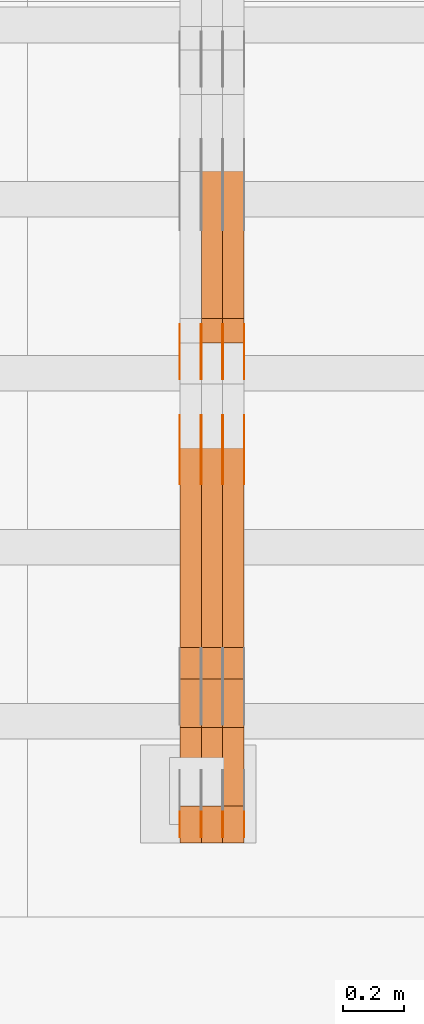
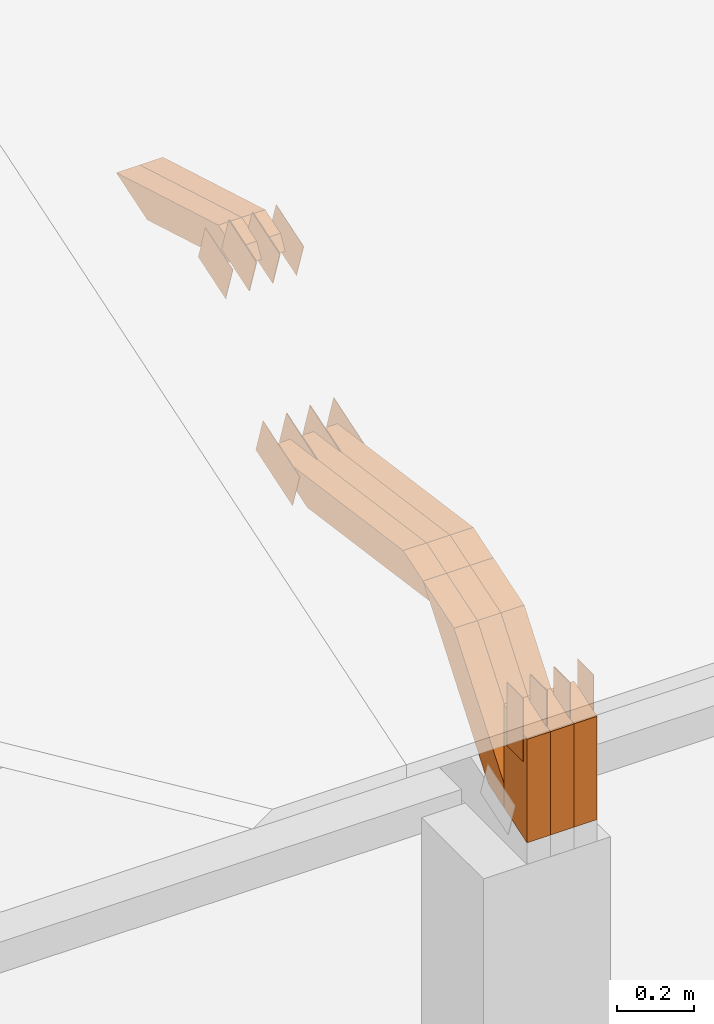
# One storey, part 122 of 385: 29 proxies.
"""IFC2X3 building model written with IfcOpenShell, lengths in millimetres."""

from ifc_helpers import new_model, entity, si_unit, converted_unit, derived_unit, direction, frame, frame_2d, origin, place, context, subcontext, project, spatial, polyline, rectangle, outline, extrude, source, transform, mapped, material, type_object, type_shapes, element, save


model = new_model("IFC2X3")

# Units and contexts
model_context = context("Model", 3, precision=0.01, world=origin(), true_north=direction((6.12303176911189e-17, 1.0)))
body_context = subcontext(model_context, "Body", "Model", "MODEL_VIEW")
ifc_project = project(units=[si_unit("LENGTHUNIT", "METRE", prefix="MILLI"), si_unit("AREAUNIT", "SQUARE_METRE"), si_unit("VOLUMEUNIT", "CUBIC_METRE"), converted_unit("PLANEANGLEUNIT", "DEGREE", entity("IfcRatioMeasure", 0.0174532925199433), si_unit("PLANEANGLEUNIT", "RADIAN"), dimensions=[0, 0, 0, 0, 0, 0, 0]), si_unit("MASSUNIT", "GRAM", prefix="KILO"), derived_unit("MASSDENSITYUNIT", [(si_unit("MASSUNIT", "GRAM", prefix="KILO"), 1), (si_unit("LENGTHUNIT", "METRE"), -3)]), si_unit("TIMEUNIT", "SECOND"), si_unit("FREQUENCYUNIT", "HERTZ"), si_unit("THERMODYNAMICTEMPERATUREUNIT", "DEGREE_CELSIUS"), derived_unit("THERMALTRANSMITTANCEUNIT", [(si_unit("MASSUNIT", "GRAM", prefix="KILO"), 1), (si_unit("THERMODYNAMICTEMPERATUREUNIT", "KELVIN"), -1), (si_unit("TIMEUNIT", "SECOND"), -3)]), derived_unit("VOLUMETRICFLOWRATEUNIT", [(si_unit("LENGTHUNIT", "METRE"), 3), (si_unit("TIMEUNIT", "SECOND"), -1)]), si_unit("ELECTRICCURRENTUNIT", "AMPERE"), si_unit("ELECTRICVOLTAGEUNIT", "VOLT"), si_unit("POWERUNIT", "WATT"), si_unit("FORCEUNIT", "NEWTON", prefix="KILO"), si_unit("ILLUMINANCEUNIT", "LUX"), si_unit("LUMINOUSFLUXUNIT", "LUMEN"), si_unit("LUMINOUSINTENSITYUNIT", "CANDELA"), derived_unit("USERDEFINED", [(si_unit("MASSUNIT", "GRAM", prefix="KILO"), -1), (si_unit("LENGTHUNIT", "METRE"), -2), (si_unit("TIMEUNIT", "SECOND"), 3), (si_unit("LUMINOUSFLUXUNIT", "LUMEN"), 1)]), derived_unit("LINEARVELOCITYUNIT", [(si_unit("LENGTHUNIT", "METRE"), 1), (si_unit("TIMEUNIT", "SECOND"), -1)]), si_unit("PRESSUREUNIT", "PASCAL"), derived_unit("USERDEFINED", [(si_unit("LENGTHUNIT", "METRE"), -2), (si_unit("MASSUNIT", "GRAM", prefix="KILO"), 1), (si_unit("TIMEUNIT", "SECOND"), -2)])], contexts=[model_context])

# Site, building, storey
site_placement = place(None, origin())
site = spatial("IfcSite", under=ifc_project, at=site_placement, CompositionType="ELEMENT")
building_placement = place(site_placement, origin())
building = spatial("IfcBuilding", under=site, at=building_placement, CompositionType="ELEMENT")
storey_placement = place(building_placement, origin())
storey = spatial("IfcBuildingStorey", under=building, at=storey_placement, Name="Default", CompositionType="ELEMENT", Elevation=0.0)

# Proxies
ifc_material_1 = material(Name="IfcSurfaceStyle #305254")
building_element_proxy_type_1 = type_object("IfcBuildingElementProxyType", PredefinedType="NOTDEFINED", material=ifc_material_1)
shared_shape_1 = source(origin(), body_context, "Body", "SweptSolid", [
    extrude(outline(polyline([(-99.9998204243802, -60.000067376167), (99.9998338462265, -60.000067376167), (99.9998204243802, 60.000067376167), (-99.9998338462265, 60.000067376167), (-99.9998204243802, -60.000067376167)])), frame((100.000602015329, 60.0001864986889, 0.0), z_axis=(0.0, 0.0, 1.0), x_axis=(-1.0, 0.0, 0.0)), (0.0, 0.0, 1.0), 1.3),
])
type_shapes(building_element_proxy_type_1, [shared_shape_1])
proxy_1_placement = place(building_placement, frame((24386.3, 4114.85465165112, 513.097031388771), z_axis=(-1.0, 0.0, 0.0), x_axis=(0.0, 0.951056516295124, 0.309016994375039)))
element("IfcBuildingElementProxy", 1, at=proxy_1_placement, inside=storey, type_object=building_element_proxy_type_1, material=ifc_material_1, context=body_context, shape_type="MappedRepresentation", body=[
    mapped(shared_shape_1, transform((0.0, 0.0, 0.0), scale=1.0)),
])
ifc_material_2 = material(Name="IfcSurfaceStyle #305197")
building_element_proxy_type_2 = type_object("IfcBuildingElementProxyType", PredefinedType="NOTDEFINED", material=ifc_material_2)
shared_shape_2 = source(origin(), body_context, "Body", "SweptSolid", [
    extrude(outline(polyline([(-99.9998204243802, -60.000067376167), (99.9998338462265, -60.000067376167), (99.9998204243802, 60.000067376167), (-99.9998338462265, 60.000067376167), (-99.9998204243802, -60.000067376167)])), frame((100.000602015329, 60.0001864986889, 0.0), z_axis=(0.0, 0.0, 1.0), x_axis=(-1.0, 0.0, 0.0)), (0.0, 0.0, 1.0), 1.3),
])
type_shapes(building_element_proxy_type_2, [shared_shape_2])
proxy_2_placement = place(building_placement, frame((24315.0, 4114.85465165112, 513.097031388771), z_axis=(-1.0, 0.0, 0.0), x_axis=(0.0, 0.951056516295124, 0.309016994375039)))
element("IfcBuildingElementProxy", 2, at=proxy_2_placement, inside=storey, type_object=building_element_proxy_type_2, material=ifc_material_2, context=body_context, shape_type="MappedRepresentation", body=[
    mapped(shared_shape_2, transform((0.0, 0.0, 0.0), scale=1.0)),
])
ifc_material_3 = material(Name="IfcSurfaceStyle #305140")
building_element_proxy_type_3 = type_object("IfcBuildingElementProxyType", PredefinedType="NOTDEFINED", material=ifc_material_3)
shared_shape_3 = source(origin(), body_context, "Body", "SweptSolid", [
    extrude(outline(polyline([(-99.9998204243802, -60.000067376167), (99.9998338462265, -60.000067376167), (99.9998204243802, 60.000067376167), (-99.9998338462265, 60.000067376167), (-99.9998204243802, -60.000067376167)])), frame((100.000602015329, 60.0001864986889, 0.0), z_axis=(0.0, 0.0, 1.0), x_axis=(-1.0, 0.0, 0.0)), (0.0, 0.0, 1.0), 1.3),
])
type_shapes(building_element_proxy_type_3, [shared_shape_3])
proxy_3_placement = place(building_placement, frame((24316.3, 4114.85465165112, 513.097031388771), z_axis=(-1.0, 0.0, 0.0), x_axis=(0.0, 0.951056516295124, 0.309016994375039)))
element("IfcBuildingElementProxy", 3, at=proxy_3_placement, inside=storey, type_object=building_element_proxy_type_3, material=ifc_material_3, context=body_context, shape_type="MappedRepresentation", body=[
    mapped(shared_shape_3, transform((0.0, 0.0, 0.0), scale=1.0)),
])
ifc_material_4 = material(Name="IfcSurfaceStyle #305083")
building_element_proxy_type_4 = type_object("IfcBuildingElementProxyType", PredefinedType="NOTDEFINED", material=ifc_material_4)
shared_shape_4 = source(origin(), body_context, "Body", "SweptSolid", [
    extrude(outline(polyline([(-99.9998204243802, -60.000067376167), (99.9998338462265, -60.000067376167), (99.9998204243802, 60.000067376167), (-99.9998338462265, 60.000067376167), (-99.9998204243802, -60.000067376167)])), frame((100.000602015329, 60.0001864986889, 0.0), z_axis=(0.0, 0.0, 1.0), x_axis=(-1.0, 0.0, 0.0)), (0.0, 0.0, 1.0), 1.29999999999998),
])
type_shapes(building_element_proxy_type_4, [shared_shape_4])
proxy_4_placement = place(building_placement, frame((24245.0, 4114.85465165112, 513.097031388771), z_axis=(-1.0, 0.0, 0.0), x_axis=(0.0, 0.951056516295124, 0.309016994375039)))
element("IfcBuildingElementProxy", 4, at=proxy_4_placement, inside=storey, type_object=building_element_proxy_type_4, material=ifc_material_4, context=body_context, shape_type="MappedRepresentation", body=[
    mapped(shared_shape_4, transform((0.0, 0.0, 0.0), scale=1.0)),
])
ifc_material_5 = material(Name="IfcSurfaceStyle #305026")
building_element_proxy_type_5 = type_object("IfcBuildingElementProxyType", PredefinedType="NOTDEFINED", material=ifc_material_5)
shared_shape_5 = source(origin(), body_context, "Body", "SweptSolid", [
    extrude(outline(polyline([(-99.9998204243802, -60.000067376167), (99.9998338462265, -60.000067376167), (99.9998204243802, 60.000067376167), (-99.9998338462265, 60.000067376167), (-99.9998204243802, -60.000067376167)])), frame((100.000602015329, 60.0001864986889, 0.0), z_axis=(0.0, 0.0, 1.0), x_axis=(-1.0, 0.0, 0.0)), (0.0, 0.0, 1.0), 1.29999999999998),
])
type_shapes(building_element_proxy_type_5, [shared_shape_5])
proxy_5_placement = place(building_placement, frame((24246.3, 4114.85465165112, 513.097031388771), z_axis=(-1.0, 0.0, 0.0), x_axis=(0.0, 0.951056516295124, 0.309016994375039)))
element("IfcBuildingElementProxy", 5, at=proxy_5_placement, inside=storey, type_object=building_element_proxy_type_5, material=ifc_material_5, context=body_context, shape_type="MappedRepresentation", body=[
    mapped(shared_shape_5, transform((0.0, 0.0, 0.0), scale=1.0)),
])
ifc_material_6 = material(Name="IfcSurfaceStyle #304969")
building_element_proxy_type_6 = type_object("IfcBuildingElementProxyType", PredefinedType="NOTDEFINED", material=ifc_material_6)
shared_shape_6 = source(origin(), body_context, "Body", "SweptSolid", [
    extrude(outline(polyline([(-99.9998204243802, -60.000067376167), (99.9998338462265, -60.000067376167), (99.9998204243802, 60.000067376167), (-99.9998338462265, 60.000067376167), (-99.9998204243802, -60.000067376167)])), frame((100.000602015329, 60.0001864986889, 0.0), z_axis=(0.0, 0.0, 1.0), x_axis=(-1.0, 0.0, 0.0)), (0.0, 0.0, 1.0), 1.29999999999999),
])
type_shapes(building_element_proxy_type_6, [shared_shape_6])
proxy_6_placement = place(building_placement, frame((24175.0, 4114.85465165112, 513.097031388771), z_axis=(-1.0, 0.0, 0.0), x_axis=(0.0, 0.951056516295124, 0.309016994375039)))
element("IfcBuildingElementProxy", 6, at=proxy_6_placement, inside=storey, type_object=building_element_proxy_type_6, material=ifc_material_6, context=body_context, shape_type="MappedRepresentation", body=[
    mapped(shared_shape_6, transform((0.0, 0.0, 0.0), scale=1.0)),
])
ifc_material_7 = material(Name="IfcSurfaceStyle #298072")
building_element_proxy_type_7 = type_object("IfcBuildingElementProxyType", PredefinedType="NOTDEFINED", material=ifc_material_7)
shared_shape_7 = source(origin(), body_context, "Body", "SweptSolid", [
    extrude(outline(polyline([(-74.999865998172, -60.0000306612919), (74.999869989555, -60.0000306612919), (74.999865998172, 60.0000306612919), (-74.999869989555, 60.0000306612919), (-74.999865998172, -60.0000306612919)])), frame((75.0006726017528, 60.0001996460842, 0.0), z_axis=(0.0, 0.0, 1.0), x_axis=(-1.0, 0.0, 0.0)), (0.0, 0.0, 1.0), 1.3),
])
type_shapes(building_element_proxy_type_7, [shared_shape_7])
proxy_7_placement = place(building_placement, frame((24386.3, 4460.38978242656, 957.314497110567), z_axis=(-1.0, 0.0, 0.0), x_axis=(0.0, 0.951056516295154, 0.309016994374948)))
element("IfcBuildingElementProxy", 7, at=proxy_7_placement, inside=storey, type_object=building_element_proxy_type_7, material=ifc_material_7, context=body_context, shape_type="MappedRepresentation", body=[
    mapped(shared_shape_7, transform((0.0, 0.0, 0.0), scale=1.0)),
])
ifc_material_8 = material(Name="IfcSurfaceStyle #298015")
building_element_proxy_type_8 = type_object("IfcBuildingElementProxyType", PredefinedType="NOTDEFINED", material=ifc_material_8)
shared_shape_8 = source(origin(), body_context, "Body", "SweptSolid", [
    extrude(outline(polyline([(-74.999865998172, -60.0000306612919), (74.999869989555, -60.0000306612919), (74.999865998172, 60.0000306612919), (-74.999869989555, 60.0000306612919), (-74.999865998172, -60.0000306612919)])), frame((75.0006726017528, 60.0001996460842, 0.0), z_axis=(0.0, 0.0, 1.0), x_axis=(-1.0, 0.0, 0.0)), (0.0, 0.0, 1.0), 1.3),
])
type_shapes(building_element_proxy_type_8, [shared_shape_8])
proxy_8_placement = place(building_placement, frame((24315.0, 4460.38978242656, 957.314497110567), z_axis=(-1.0, 0.0, 0.0), x_axis=(0.0, 0.951056516295154, 0.309016994374948)))
element("IfcBuildingElementProxy", 8, at=proxy_8_placement, inside=storey, type_object=building_element_proxy_type_8, material=ifc_material_8, context=body_context, shape_type="MappedRepresentation", body=[
    mapped(shared_shape_8, transform((0.0, 0.0, 0.0), scale=1.0)),
])
ifc_material_9 = material(Name="IfcSurfaceStyle #297958")
building_element_proxy_type_9 = type_object("IfcBuildingElementProxyType", PredefinedType="NOTDEFINED", material=ifc_material_9)
shared_shape_9 = source(origin(), body_context, "Body", "SweptSolid", [
    extrude(outline(polyline([(-74.999865998172, -60.0000306612919), (74.999869989555, -60.0000306612919), (74.999865998172, 60.0000306612919), (-74.999869989555, 60.0000306612919), (-74.999865998172, -60.0000306612919)])), frame((75.0006726017528, 60.0001996460842, 0.0), z_axis=(0.0, 0.0, 1.0), x_axis=(-1.0, 0.0, 0.0)), (0.0, 0.0, 1.0), 1.3),
])
type_shapes(building_element_proxy_type_9, [shared_shape_9])
proxy_9_placement = place(building_placement, frame((24316.3, 4460.38978242656, 957.314497110567), z_axis=(-1.0, 0.0, 0.0), x_axis=(0.0, 0.951056516295154, 0.309016994374948)))
element("IfcBuildingElementProxy", 9, at=proxy_9_placement, inside=storey, type_object=building_element_proxy_type_9, material=ifc_material_9, context=body_context, shape_type="MappedRepresentation", body=[
    mapped(shared_shape_9, transform((0.0, 0.0, 0.0), scale=1.0)),
])
ifc_material_10 = material(Name="IfcSurfaceStyle #297901")
building_element_proxy_type_10 = type_object("IfcBuildingElementProxyType", PredefinedType="NOTDEFINED", material=ifc_material_10)
shared_shape_10 = source(origin(), body_context, "Body", "SweptSolid", [
    extrude(outline(polyline([(-74.999865998172, -60.0000306612919), (74.999869989555, -60.0000306612919), (74.999865998172, 60.0000306612919), (-74.999869989555, 60.0000306612919), (-74.999865998172, -60.0000306612919)])), frame((75.0006726017528, 60.0001996460842, 0.0), z_axis=(0.0, 0.0, 1.0), x_axis=(-1.0, 0.0, 0.0)), (0.0, 0.0, 1.0), 1.29999999999999),
])
type_shapes(building_element_proxy_type_10, [shared_shape_10])
proxy_10_placement = place(building_placement, frame((24245.0, 4460.38978242656, 957.314497110567), z_axis=(-1.0, 0.0, 0.0), x_axis=(0.0, 0.951056516295154, 0.309016994374948)))
element("IfcBuildingElementProxy", 10, at=proxy_10_placement, inside=storey, type_object=building_element_proxy_type_10, material=ifc_material_10, context=body_context, shape_type="MappedRepresentation", body=[
    mapped(shared_shape_10, transform((0.0, 0.0, 0.0), scale=1.0)),
])
ifc_material_11 = material(Name="IfcSurfaceStyle #297844")
building_element_proxy_type_11 = type_object("IfcBuildingElementProxyType", PredefinedType="NOTDEFINED", material=ifc_material_11)
shared_shape_11 = source(origin(), body_context, "Body", "SweptSolid", [
    extrude(outline(polyline([(-74.999865998172, -60.0000306612919), (74.999869989555, -60.0000306612919), (74.999865998172, 60.0000306612919), (-74.999869989555, 60.0000306612919), (-74.999865998172, -60.0000306612919)])), frame((75.0006726017528, 60.0001996460842, 0.0), z_axis=(0.0, 0.0, 1.0), x_axis=(-1.0, 0.0, 0.0)), (0.0, 0.0, 1.0), 1.29999999999999),
])
type_shapes(building_element_proxy_type_11, [shared_shape_11])
proxy_11_placement = place(building_placement, frame((24246.3, 4460.38978242656, 957.314497110567), z_axis=(-1.0, 0.0, 0.0), x_axis=(0.0, 0.951056516295154, 0.309016994374948)))
element("IfcBuildingElementProxy", 11, at=proxy_11_placement, inside=storey, type_object=building_element_proxy_type_11, material=ifc_material_11, context=body_context, shape_type="MappedRepresentation", body=[
    mapped(shared_shape_11, transform((0.0, 0.0, 0.0), scale=1.0)),
])
ifc_material_12 = material(Name="IfcSurfaceStyle #297787")
building_element_proxy_type_12 = type_object("IfcBuildingElementProxyType", PredefinedType="NOTDEFINED", material=ifc_material_12)
shared_shape_12 = source(origin(), body_context, "Body", "SweptSolid", [
    extrude(outline(polyline([(-74.999865998172, -60.0000306612919), (74.999869989555, -60.0000306612919), (74.999865998172, 60.0000306612919), (-74.999869989555, 60.0000306612919), (-74.999865998172, -60.0000306612919)])), frame((75.0006726017528, 60.0001996460842, 0.0), z_axis=(0.0, 0.0, 1.0), x_axis=(-1.0, 0.0, 0.0)), (0.0, 0.0, 1.0), 1.29999999999999),
])
type_shapes(building_element_proxy_type_12, [shared_shape_12])
proxy_12_placement = place(building_placement, frame((24175.0, 4460.38978242656, 957.314497110567), z_axis=(-1.0, 0.0, 0.0), x_axis=(0.0, 0.951056516295154, 0.309016994374948)))
element("IfcBuildingElementProxy", 12, at=proxy_12_placement, inside=storey, type_object=building_element_proxy_type_12, material=ifc_material_12, context=body_context, shape_type="MappedRepresentation", body=[
    mapped(shared_shape_12, transform((0.0, 0.0, 0.0), scale=1.0)),
])
ifc_material_13 = material(Name="IfcSurfaceStyle #296020")
building_element_proxy_type_13 = type_object("IfcBuildingElementProxyType", PredefinedType="NOTDEFINED", material=ifc_material_13)
shared_shape_13 = source(origin(), body_context, "Body", "SweptSolid", [
    extrude(rectangle(XDim=199.999969482422, YDim=84.0, at=frame_2d((1.4210854715202e-14, 0.0), x_axis=(1.0, 0.0))), frame((100.000010815955, 42.0, 0.0), z_axis=(0.0, 0.0, 1.0), x_axis=(-1.0, 0.0, 0.0)), (0.0, 0.0, 1.0), 1.3),
])
type_shapes(building_element_proxy_type_13, [shared_shape_13])
proxy_13_placement = place(building_placement, frame((24386.3, 3042.0, 514.460048047401), z_axis=(-1.0, 0.0, 0.0), x_axis=(0.0, 0.0, -1.0)))
element("IfcBuildingElementProxy", 13, at=proxy_13_placement, inside=storey, type_object=building_element_proxy_type_13, material=ifc_material_13, context=body_context, shape_type="MappedRepresentation", body=[
    mapped(shared_shape_13, transform((0.0, 0.0, 0.0), scale=1.0)),
])
ifc_material_14 = material(Name="IfcSurfaceStyle #295963")
building_element_proxy_type_14 = type_object("IfcBuildingElementProxyType", PredefinedType="NOTDEFINED", material=ifc_material_14)
shared_shape_14 = source(origin(), body_context, "Body", "SweptSolid", [
    extrude(rectangle(XDim=199.999969482422, YDim=84.0, at=frame_2d((1.4210854715202e-14, 0.0), x_axis=(1.0, 0.0))), frame((100.000010815955, 42.0, 0.0), z_axis=(0.0, 0.0, 1.0), x_axis=(-1.0, 0.0, 0.0)), (0.0, 0.0, 1.0), 1.3),
])
type_shapes(building_element_proxy_type_14, [shared_shape_14])
proxy_14_placement = place(building_placement, frame((24315.0, 3042.0, 514.460048047401), z_axis=(-1.0, 0.0, 0.0), x_axis=(0.0, 0.0, -1.0)))
element("IfcBuildingElementProxy", 14, at=proxy_14_placement, inside=storey, type_object=building_element_proxy_type_14, material=ifc_material_14, context=body_context, shape_type="MappedRepresentation", body=[
    mapped(shared_shape_14, transform((0.0, 0.0, 0.0), scale=1.0)),
])
ifc_material_15 = material(Name="IfcSurfaceStyle #295906")
building_element_proxy_type_15 = type_object("IfcBuildingElementProxyType", PredefinedType="NOTDEFINED", material=ifc_material_15)
shared_shape_15 = source(origin(), body_context, "Body", "SweptSolid", [
    extrude(rectangle(XDim=199.999969482422, YDim=84.0, at=frame_2d((1.4210854715202e-14, 0.0), x_axis=(1.0, 0.0))), frame((100.000010815955, 42.0, 0.0), z_axis=(0.0, 0.0, 1.0), x_axis=(-1.0, 0.0, 0.0)), (0.0, 0.0, 1.0), 1.3),
])
type_shapes(building_element_proxy_type_15, [shared_shape_15])
proxy_15_placement = place(building_placement, frame((24316.3, 3042.0, 514.460048047401), z_axis=(-1.0, 0.0, 0.0), x_axis=(0.0, 0.0, -1.0)))
element("IfcBuildingElementProxy", 15, at=proxy_15_placement, inside=storey, type_object=building_element_proxy_type_15, material=ifc_material_15, context=body_context, shape_type="MappedRepresentation", body=[
    mapped(shared_shape_15, transform((0.0, 0.0, 0.0), scale=1.0)),
])
ifc_material_16 = material(Name="IfcSurfaceStyle #295849")
building_element_proxy_type_16 = type_object("IfcBuildingElementProxyType", PredefinedType="NOTDEFINED", material=ifc_material_16)
shared_shape_16 = source(origin(), body_context, "Body", "SweptSolid", [
    extrude(rectangle(XDim=199.999969482422, YDim=84.0, at=frame_2d((1.4210854715202e-14, 0.0), x_axis=(1.0, 0.0))), frame((100.000010815955, 42.0, 0.0), z_axis=(0.0, 0.0, 1.0), x_axis=(-1.0, 0.0, 0.0)), (0.0, 0.0, 1.0), 1.29999999999998),
])
type_shapes(building_element_proxy_type_16, [shared_shape_16])
proxy_16_placement = place(building_placement, frame((24245.0, 3042.0, 514.460048047401), z_axis=(-1.0, 0.0, 0.0), x_axis=(0.0, 0.0, -1.0)))
element("IfcBuildingElementProxy", 16, at=proxy_16_placement, inside=storey, type_object=building_element_proxy_type_16, material=ifc_material_16, context=body_context, shape_type="MappedRepresentation", body=[
    mapped(shared_shape_16, transform((0.0, 0.0, 0.0), scale=1.0)),
])
ifc_material_17 = material(Name="IfcSurfaceStyle #295792")
building_element_proxy_type_17 = type_object("IfcBuildingElementProxyType", PredefinedType="NOTDEFINED", material=ifc_material_17)
shared_shape_17 = source(origin(), body_context, "Body", "SweptSolid", [
    extrude(rectangle(XDim=199.999969482422, YDim=84.0, at=frame_2d((1.4210854715202e-14, 0.0), x_axis=(1.0, 0.0))), frame((100.000010815955, 42.0, 0.0), z_axis=(0.0, 0.0, 1.0), x_axis=(-1.0, 0.0, 0.0)), (0.0, 0.0, 1.0), 1.29999999999998),
])
type_shapes(building_element_proxy_type_17, [shared_shape_17])
proxy_17_placement = place(building_placement, frame((24246.3, 3042.0, 514.460048047401), z_axis=(-1.0, 0.0, 0.0), x_axis=(0.0, 0.0, -1.0)))
element("IfcBuildingElementProxy", 17, at=proxy_17_placement, inside=storey, type_object=building_element_proxy_type_17, material=ifc_material_17, context=body_context, shape_type="MappedRepresentation", body=[
    mapped(shared_shape_17, transform((0.0, 0.0, 0.0), scale=1.0)),
])
ifc_material_18 = material(Name="IfcSurfaceStyle #295735")
building_element_proxy_type_18 = type_object("IfcBuildingElementProxyType", PredefinedType="NOTDEFINED", material=ifc_material_18)
shared_shape_18 = source(origin(), body_context, "Body", "SweptSolid", [
    extrude(rectangle(XDim=199.999969482422, YDim=84.0, at=frame_2d((1.4210854715202e-14, 0.0), x_axis=(1.0, 0.0))), frame((100.000010815955, 42.0, 0.0), z_axis=(0.0, 0.0, 1.0), x_axis=(-1.0, 0.0, 0.0)), (0.0, 0.0, 1.0), 1.29999999999999),
])
type_shapes(building_element_proxy_type_18, [shared_shape_18])
proxy_18_placement = place(building_placement, frame((24175.0, 3042.0, 514.460048047401), z_axis=(-1.0, 0.0, 0.0), x_axis=(0.0, 0.0, -1.0)))
element("IfcBuildingElementProxy", 18, at=proxy_18_placement, inside=storey, type_object=building_element_proxy_type_18, material=ifc_material_18, context=body_context, shape_type="MappedRepresentation", body=[
    mapped(shared_shape_18, transform((0.0, 0.0, 0.0), scale=1.0)),
])
ifc_material_19 = material(Name="IfcSurfaceStyle #285544")
building_element_proxy_type_19 = type_object("IfcBuildingElementProxyType", Name="T1-W12 285542", PredefinedType="NOTDEFINED", material=ifc_material_19)
shared_shape_19 = source(origin(), body_context, "Body", "SweptSolid", [
    extrude(outline(polyline([(-249.405625983165, -47.5001691155616), (243.345753908996, -47.5001691155616), (232.115534842595, 2.39993474701938e-05), (162.527010966644, 47.5001571158879), (-388.58267373507, 47.5001571158879), (-249.405625983165, -47.5001691155616)])), frame((243.345867653852, 47.5001571158879, 0.0), z_axis=(0.0, 0.0, 1.0), x_axis=(-1.0, 0.0, 0.0)), (0.0, 0.0, 1.0), 70.0),
])
type_shapes(building_element_proxy_type_19, [shared_shape_19])
proxy_19_placement = place(building_placement, frame((24385.0, 4581.32698473631, 976.172276753357), z_axis=(-1.0, 0.0, 0.0), x_axis=(0.0, 0.959722067881787, -0.280951156645966)))
element("IfcBuildingElementProxy", 19, at=proxy_19_placement, inside=storey, type_object=building_element_proxy_type_19, material=ifc_material_19, Name="T1-W12", context=body_context, shape_type="MappedRepresentation", body=[
    mapped(shared_shape_19, transform((0.0, 0.0, 0.0), scale=1.0)),
])
ifc_material_20 = material(Name="IfcSurfaceStyle #285478")
building_element_proxy_type_20 = type_object("IfcBuildingElementProxyType", Name="T1-W12 285476", PredefinedType="NOTDEFINED", material=ifc_material_20)
shared_shape_20 = source(origin(), body_context, "Body", "SweptSolid", [
    extrude(outline(polyline([(-249.405625983165, -47.5001691155616), (243.345753908996, -47.5001691155616), (232.115534842595, 2.39993474701938e-05), (162.527010966644, 47.5001571158879), (-388.58267373507, 47.5001571158879), (-249.405625983165, -47.5001691155616)])), frame((243.345867653852, 47.5001571158879, 0.0), z_axis=(0.0, 0.0, 1.0), x_axis=(-1.0, 0.0, 0.0)), (0.0, 0.0, 1.0), 70.0),
])
type_shapes(building_element_proxy_type_20, [shared_shape_20])
proxy_20_placement = place(building_placement, frame((24315.0, 4581.32698473631, 976.172276753357), z_axis=(-1.0, 0.0, 0.0), x_axis=(0.0, 0.959722067881787, -0.280951156645966)))
element("IfcBuildingElementProxy", 20, at=proxy_20_placement, inside=storey, type_object=building_element_proxy_type_20, material=ifc_material_20, Name="T1-W12", context=body_context, shape_type="MappedRepresentation", body=[
    mapped(shared_shape_20, transform((0.0, 0.0, 0.0), scale=1.0)),
])
ifc_material_21 = material(Name="IfcSurfaceStyle #284752")
building_element_proxy_type_21 = type_object("IfcBuildingElementProxyType", Name="T1-W3 284750", PredefinedType="NOTDEFINED", material=ifc_material_21)
shared_shape_21 = source(origin(), body_context, "Body", "SweptSolid", [
    extrude(outline(polyline([(-314.232579911788, -47.5000200125938), (325.164873061766, -47.5000200125938), (297.999869081008, 6.48085173424295e-05), (200.434027234171, 47.4999876083351), (-509.366189465157, 47.4999876083352), (-314.232579911788, -47.5000200125938)])), frame((325.164873061766, 47.5001564752191, 0.0), z_axis=(0.0, 0.0, 1.0), x_axis=(-1.0, 0.0, 0.0)), (0.0, 0.0, 1.0), 70.0),
])
type_shapes(building_element_proxy_type_21, [shared_shape_21])
proxy_21_placement = place(building_placement, frame((24385.0, 3457.43747924875, 620.49890325051), z_axis=(-1.0, 0.0, 0.0), x_axis=(0.0, 0.990367219823621, -0.138465771578512)))
element("IfcBuildingElementProxy", 21, at=proxy_21_placement, inside=storey, type_object=building_element_proxy_type_21, material=ifc_material_21, Name="T1-W3", context=body_context, shape_type="MappedRepresentation", body=[
    mapped(shared_shape_21, transform((0.0, 0.0, 0.0), scale=1.0)),
])
ifc_material_22 = material(Name="IfcSurfaceStyle #284686")
building_element_proxy_type_22 = type_object("IfcBuildingElementProxyType", Name="T1-W3 284684", PredefinedType="NOTDEFINED", material=ifc_material_22)
shared_shape_22 = source(origin(), body_context, "Body", "SweptSolid", [
    extrude(outline(polyline([(-314.232579911788, -47.5000200125938), (325.164873061766, -47.5000200125938), (297.999869081008, 6.48085173424295e-05), (200.434027234171, 47.4999876083351), (-509.366189465157, 47.4999876083352), (-314.232579911788, -47.5000200125938)])), frame((325.164873061766, 47.5001564752191, 0.0), z_axis=(0.0, 0.0, 1.0), x_axis=(-1.0, 0.0, 0.0)), (0.0, 0.0, 1.0), 70.0),
])
type_shapes(building_element_proxy_type_22, [shared_shape_22])
proxy_22_placement = place(building_placement, frame((24315.0, 3457.43747924875, 620.49890325051), z_axis=(-1.0, 0.0, 0.0), x_axis=(0.0, 0.990367219823621, -0.138465771578512)))
element("IfcBuildingElementProxy", 22, at=proxy_22_placement, inside=storey, type_object=building_element_proxy_type_22, material=ifc_material_22, Name="T1-W3", context=body_context, shape_type="MappedRepresentation", body=[
    mapped(shared_shape_22, transform((0.0, 0.0, 0.0), scale=1.0)),
])
ifc_material_23 = material(Name="IfcSurfaceStyle #284620")
building_element_proxy_type_23 = type_object("IfcBuildingElementProxyType", Name="T1-W3 284618", PredefinedType="NOTDEFINED", material=ifc_material_23)
shared_shape_23 = source(origin(), body_context, "Body", "SweptSolid", [
    extrude(outline(polyline([(-314.232579911788, -47.5000200125938), (325.164873061766, -47.5000200125938), (297.999869081008, 6.48085173424295e-05), (200.434027234171, 47.4999876083351), (-509.366189465157, 47.4999876083352), (-314.232579911788, -47.5000200125938)])), frame((325.164873061766, 47.5001564752191, 0.0), z_axis=(0.0, 0.0, 1.0), x_axis=(-1.0, 0.0, 0.0)), (0.0, 0.0, 1.0), 70.0),
])
type_shapes(building_element_proxy_type_23, [shared_shape_23])
proxy_23_placement = place(building_placement, frame((24245.0, 3457.43747924875, 620.49890325051), z_axis=(-1.0, 0.0, 0.0), x_axis=(0.0, 0.990367219823621, -0.138465771578512)))
element("IfcBuildingElementProxy", 23, at=proxy_23_placement, inside=storey, type_object=building_element_proxy_type_23, material=ifc_material_23, Name="T1-W3", context=body_context, shape_type="MappedRepresentation", body=[
    mapped(shared_shape_23, transform((0.0, 0.0, 0.0), scale=1.0)),
])
ifc_material_24 = material(Name="IfcSurfaceStyle #284356")
building_element_proxy_type_24 = type_object("IfcBuildingElementProxyType", Name="T1-W14 284354", PredefinedType="NOTDEFINED", material=ifc_material_24)
shared_shape_24 = source(origin(), body_context, "Body", "SweptSolid", [
    extrude(outline(polyline([(-374.484689776928, -47.499919737532), (177.199556189275, -47.499919737532), (246.893257937645, -5.36774925340877e-05), (185.487930694801, 47.4999465762783), (-235.096055044793, 47.4999465762784), (-374.484689776928, -47.499919737532)])), frame((246.893257937645, 47.5000959779252, 0.0), z_axis=(0.0, 0.0, 1.0), x_axis=(-1.0, 0.0, 0.0)), (0.0, 0.0, 1.0), 70.0),
])
type_shapes(building_element_proxy_type_24, [shared_shape_24])
proxy_24_placement = place(building_placement, frame((24385.0, 3022.42877773024, 136.329406512195), z_axis=(-1.0, 0.0, 0.0), x_axis=(0.0, 0.611854146609475, 0.790970608352037)))
element("IfcBuildingElementProxy", 24, at=proxy_24_placement, inside=storey, type_object=building_element_proxy_type_24, material=ifc_material_24, Name="T1-W14", context=body_context, shape_type="MappedRepresentation", body=[
    mapped(shared_shape_24, transform((0.0, 0.0, 0.0), scale=1.0)),
])
ifc_material_25 = material(Name="IfcSurfaceStyle #284290")
building_element_proxy_type_25 = type_object("IfcBuildingElementProxyType", Name="T1-W14 284288", PredefinedType="NOTDEFINED", material=ifc_material_25)
shared_shape_25 = source(origin(), body_context, "Body", "SweptSolid", [
    extrude(outline(polyline([(-374.484689776928, -47.499919737532), (177.199556189275, -47.499919737532), (246.893257937645, -5.36774925340877e-05), (185.487930694801, 47.4999465762783), (-235.096055044793, 47.4999465762784), (-374.484689776928, -47.499919737532)])), frame((246.893257937645, 47.5000959779252, 0.0), z_axis=(0.0, 0.0, 1.0), x_axis=(-1.0, 0.0, 0.0)), (0.0, 0.0, 1.0), 70.0),
])
type_shapes(building_element_proxy_type_25, [shared_shape_25])
proxy_25_placement = place(building_placement, frame((24315.0, 3022.42877773024, 136.329406512195), z_axis=(-1.0, 0.0, 0.0), x_axis=(0.0, 0.611854146609475, 0.790970608352037)))
element("IfcBuildingElementProxy", 25, at=proxy_25_placement, inside=storey, type_object=building_element_proxy_type_25, material=ifc_material_25, Name="T1-W14", context=body_context, shape_type="MappedRepresentation", body=[
    mapped(shared_shape_25, transform((0.0, 0.0, 0.0), scale=1.0)),
])
ifc_material_26 = material(Name="IfcSurfaceStyle #284224")
building_element_proxy_type_26 = type_object("IfcBuildingElementProxyType", Name="T1-W14 284222", PredefinedType="NOTDEFINED", material=ifc_material_26)
shared_shape_26 = source(origin(), body_context, "Body", "SweptSolid", [
    extrude(outline(polyline([(-374.484689776928, -47.499919737532), (177.199556189275, -47.499919737532), (246.893257937645, -5.36774925340877e-05), (185.487930694801, 47.4999465762783), (-235.096055044793, 47.4999465762784), (-374.484689776928, -47.499919737532)])), frame((246.893257937645, 47.5000959779252, 0.0), z_axis=(0.0, 0.0, 1.0), x_axis=(-1.0, 0.0, 0.0)), (0.0, 0.0, 1.0), 70.0),
])
type_shapes(building_element_proxy_type_26, [shared_shape_26])
proxy_26_placement = place(building_placement, frame((24245.0, 3022.42877773024, 136.329406512195), z_axis=(-1.0, 0.0, 0.0), x_axis=(0.0, 0.611854146609475, 0.790970608352037)))
element("IfcBuildingElementProxy", 26, at=proxy_26_placement, inside=storey, type_object=building_element_proxy_type_26, material=ifc_material_26, Name="T1-W14", context=body_context, shape_type="MappedRepresentation", body=[
    mapped(shared_shape_26, transform((0.0, 0.0, 0.0), scale=1.0)),
])
ifc_material_27 = material(Name="IfcSurfaceStyle #284158")
building_element_proxy_type_27 = type_object("IfcBuildingElementProxyType", Name="T1-E3 284156", PredefinedType="NOTDEFINED", material=ifc_material_27)
shared_shape_27 = source(origin(), body_context, "Body", "SweptSolid", [
    extrude(outline(polyline([(-182.839673995971, -60.0), (143.849313735962, -60.0), (182.839677810669, 60.0), (-143.84931755066, 60.0), (-182.839673995971, -60.0)])), frame((182.839677810669, 60.0, 0.0), z_axis=(0.0, 0.0, 1.0), x_axis=(-1.0, 0.0, 0.0)), (0.0, 0.0, 1.0), 70.0),
])
type_shapes(building_element_proxy_type_27, [shared_shape_27])
proxy_27_placement = place(building_placement, frame((24385.0, 2940.0, 68.27587890625), z_axis=(-1.0, 0.0, 0.0), x_axis=(0.0, 0.0, 1.0)))
element("IfcBuildingElementProxy", 27, at=proxy_27_placement, inside=storey, type_object=building_element_proxy_type_27, material=ifc_material_27, Name="T1-E3", context=body_context, shape_type="MappedRepresentation", body=[
    mapped(shared_shape_27, transform((0.0, 0.0, 0.0), scale=1.0)),
])
ifc_material_28 = material(Name="IfcSurfaceStyle #284101")
building_element_proxy_type_28 = type_object("IfcBuildingElementProxyType", Name="T1-E3 284099", PredefinedType="NOTDEFINED", material=ifc_material_28)
shared_shape_28 = source(origin(), body_context, "Body", "SweptSolid", [
    extrude(outline(polyline([(-182.839673995971, -60.0), (143.849313735962, -60.0), (182.839677810669, 60.0), (-143.84931755066, 60.0), (-182.839673995971, -60.0)])), frame((182.839677810669, 60.0, 0.0), z_axis=(0.0, 0.0, 1.0), x_axis=(-1.0, 0.0, 0.0)), (0.0, 0.0, 1.0), 70.0),
])
type_shapes(building_element_proxy_type_28, [shared_shape_28])
proxy_28_placement = place(building_placement, frame((24315.0, 2940.0, 68.27587890625), z_axis=(-1.0, 0.0, 0.0), x_axis=(0.0, 0.0, 1.0)))
element("IfcBuildingElementProxy", 28, at=proxy_28_placement, inside=storey, type_object=building_element_proxy_type_28, material=ifc_material_28, Name="T1-E3", context=body_context, shape_type="MappedRepresentation", body=[
    mapped(shared_shape_28, transform((0.0, 0.0, 0.0), scale=1.0)),
])
ifc_material_29 = material(Name="IfcSurfaceStyle #284044")
building_element_proxy_type_29 = type_object("IfcBuildingElementProxyType", Name="T1-E3 284042", PredefinedType="NOTDEFINED", material=ifc_material_29)
shared_shape_29 = source(origin(), body_context, "Body", "SweptSolid", [
    extrude(outline(polyline([(-182.839673995971, -60.0), (143.849313735962, -60.0), (182.839677810669, 60.0), (-143.84931755066, 60.0), (-182.839673995971, -60.0)])), frame((182.839677810669, 60.0, 0.0), z_axis=(0.0, 0.0, 1.0), x_axis=(-1.0, 0.0, 0.0)), (0.0, 0.0, 1.0), 70.0),
])
type_shapes(building_element_proxy_type_29, [shared_shape_29])
proxy_29_placement = place(building_placement, frame((24245.0, 2940.0, 68.27587890625), z_axis=(-1.0, 0.0, 0.0), x_axis=(0.0, 0.0, 1.0)))
element("IfcBuildingElementProxy", 29, at=proxy_29_placement, inside=storey, type_object=building_element_proxy_type_29, material=ifc_material_29, Name="T1-E3", context=body_context, shape_type="MappedRepresentation", body=[
    mapped(shared_shape_29, transform((0.0, 0.0, 0.0), scale=1.0)),
])

save(model, "model.ifc")
